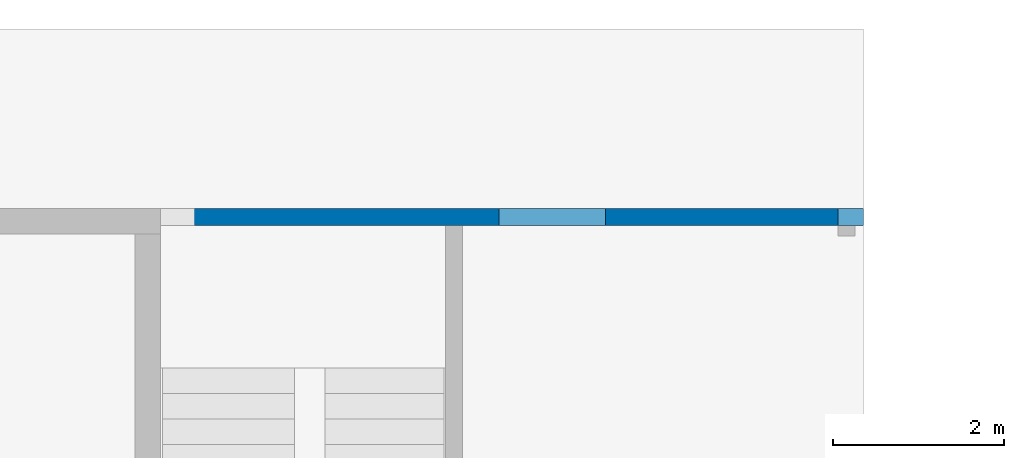
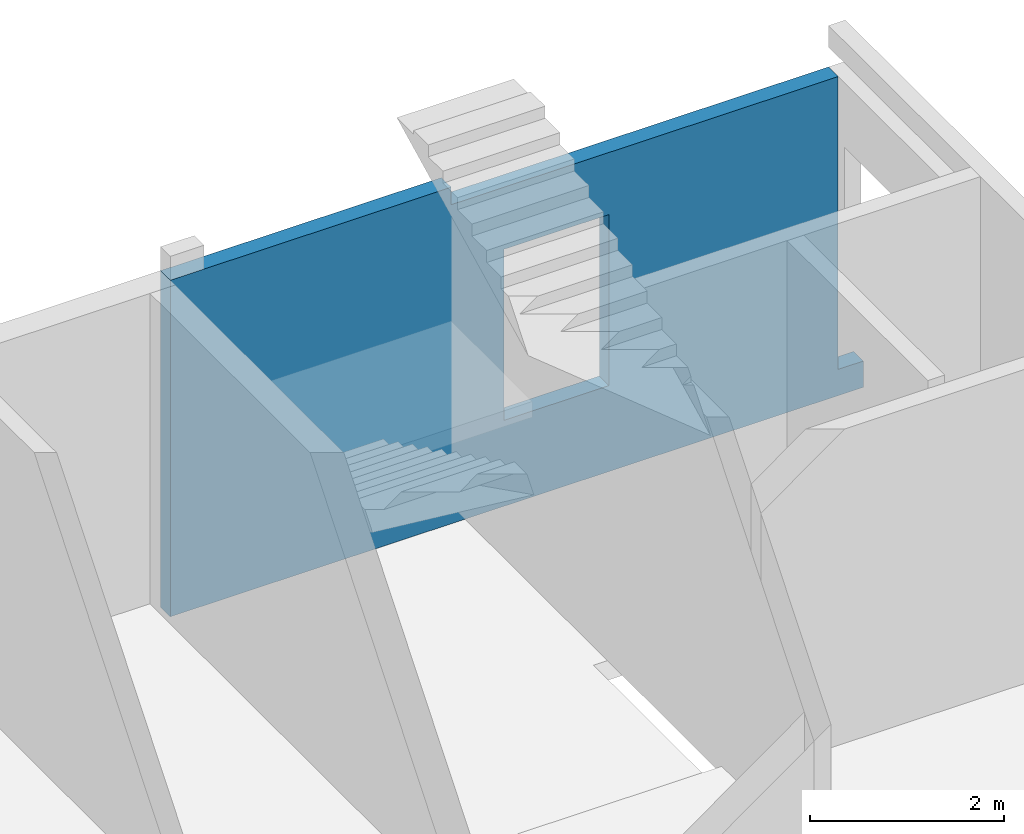
# One storey, part 8 of 8: 1 wall, 13 openings.
"""IFC4 building model written with IfcOpenShell, lengths in millimetres."""

from ifc_helpers import new_model, entity, si_unit, converted_unit, derived_unit, direction, frame, origin, place, context, subcontext, project, spatial, indexed_curve, outline, extrude, polygons, material, type_object, element, save


model = new_model("IFC4")

# Units and contexts
model_context = context("Model", 3, precision=0.01, world=origin(), true_north=direction((6.12303176911189e-17, 1.0)))
plan_context = context("Plan", 3, precision=0.01, world=origin(), true_north=direction((6.12303176911189e-17, 1.0)))
body_context = subcontext(model_context, "Body", "Model", "MODEL_VIEW")
ifc_project = project(units=[si_unit("LENGTHUNIT", "METRE", prefix="MILLI"), si_unit("AREAUNIT", "SQUARE_METRE"), si_unit("VOLUMEUNIT", "CUBIC_METRE"), converted_unit("PLANEANGLEUNIT", "DEGREE", entity("IfcRatioMeasure", 0.0174532925199433), si_unit("PLANEANGLEUNIT", "RADIAN"), dimensions=[0, 0, 0, 0, 0, 0, 0]), si_unit("MASSUNIT", "GRAM", prefix="KILO"), derived_unit("MASSDENSITYUNIT", [(si_unit("MASSUNIT", "GRAM", prefix="KILO"), 1), (si_unit("LENGTHUNIT", "METRE"), -3)]), derived_unit("MOMENTOFINERTIAUNIT", [(si_unit("LENGTHUNIT", "METRE"), 4)]), si_unit("TIMEUNIT", "SECOND"), si_unit("FREQUENCYUNIT", "HERTZ"), si_unit("THERMODYNAMICTEMPERATUREUNIT", "DEGREE_CELSIUS"), derived_unit("THERMALTRANSMITTANCEUNIT", [(si_unit("MASSUNIT", "GRAM", prefix="KILO"), 1), (si_unit("THERMODYNAMICTEMPERATUREUNIT", "KELVIN"), -1), (si_unit("TIMEUNIT", "SECOND"), -3)]), derived_unit("VOLUMETRICFLOWRATEUNIT", [(si_unit("LENGTHUNIT", "METRE"), 3), (si_unit("TIMEUNIT", "SECOND"), -1)]), derived_unit("MASSFLOWRATEUNIT", [(si_unit("MASSUNIT", "GRAM", prefix="KILO"), 1), (si_unit("TIMEUNIT", "SECOND"), -1)]), derived_unit("ROTATIONALFREQUENCYUNIT", [(si_unit("TIMEUNIT", "SECOND"), -1)]), si_unit("ELECTRICCURRENTUNIT", "AMPERE"), si_unit("ELECTRICVOLTAGEUNIT", "VOLT"), si_unit("POWERUNIT", "WATT"), si_unit("FORCEUNIT", "NEWTON", prefix="KILO"), si_unit("ILLUMINANCEUNIT", "LUX"), si_unit("LUMINOUSFLUXUNIT", "LUMEN"), si_unit("LUMINOUSINTENSITYUNIT", "CANDELA"), derived_unit("USERDEFINED", [(si_unit("MASSUNIT", "GRAM", prefix="KILO"), -1), (si_unit("LENGTHUNIT", "METRE"), -2), (si_unit("TIMEUNIT", "SECOND"), 3), (si_unit("LUMINOUSFLUXUNIT", "LUMEN"), 1)]), derived_unit("LINEARVELOCITYUNIT", [(si_unit("LENGTHUNIT", "METRE"), 1), (si_unit("TIMEUNIT", "SECOND"), -1)]), si_unit("PRESSUREUNIT", "PASCAL"), derived_unit("USERDEFINED", [(si_unit("LENGTHUNIT", "METRE"), -2), (si_unit("MASSUNIT", "GRAM", prefix="KILO"), 1), (si_unit("TIMEUNIT", "SECOND"), -2)]), derived_unit("LINEARFORCEUNIT", [(si_unit("MASSUNIT", "GRAM", prefix="KILO"), 1), (si_unit("LENGTHUNIT", "METRE"), 1), (si_unit("TIMEUNIT", "SECOND"), -2), (si_unit("LENGTHUNIT", "METRE"), -1)]), derived_unit("PLANARFORCEUNIT", [(si_unit("MASSUNIT", "GRAM", prefix="KILO"), 1), (si_unit("LENGTHUNIT", "METRE"), 1), (si_unit("TIMEUNIT", "SECOND"), -2), (si_unit("LENGTHUNIT", "METRE"), -2)])], contexts=[model_context, plan_context])

# Site, building, storey
site_placement = place(None, origin())
site = spatial("IfcSite", under=ifc_project, at=site_placement, CompositionType="ELEMENT")
building_placement = place(site_placement, origin())
building = spatial("IfcBuilding", under=site, at=building_placement, CompositionType="ELEMENT")
storey_placement = place(building_placement, origin())
storey = spatial("IfcBuildingStorey", under=building, at=storey_placement, Name="01", CompositionType="ELEMENT", Elevation=0.0)

# Wall, openings
ifc_material = material()
wall_type = type_object("IfcWallType", Name=":ADSK_ 25_200", PredefinedType="STANDARD")
wall_placement = place(storey_placement, frame((73670.0, 20400.0, -480.0), z_axis=(0.0, 0.0, 1.0), x_axis=(-1.0, 0.0, 0.0)))
wall = element("IfcWall", 1, at=wall_placement, inside=storey, type_object=wall_type, material=ifc_material, Name=":ADSK_ 25_200", ObjectType=":ADSK_ 25_200", PredefinedType="NOTDEFINED", context=body_context, shape_type="Tessellation", body=[
    polygons([(-4.19026652712969e-13, -99.9999999999989, 2.70716782324598e-13), (8240.00000000001, -99.9999999999989, 2.70716782324598e-13), (8240.00000000001, -99.9999999999989, 330.0), (8240.00000000001, -99.9999999999989, 4230.0), (7839.99999999997, -99.9999999999989, 4230.0), (4900.0, -99.9999999999946, 4230.0), (4900.0, -99.9999999999946, 4010.0), (300.000000000009, -99.9999999999989, 4010.0), (300.000000000009, -99.9999999999989, 330.0), (100.000000000012, -99.9999999999989, 330.0), (-4.19026652712969e-13, -99.9999999999989, 330.0), (3025.00000000001, -99.9999999999989, 3229.99999999804), (4275.00000000001, -99.9999999999989, 3229.99999999804), (4275.00000000001, -99.9999999999989, 1080.0), (3025.00000000001, -99.9999999999989, 1080.0), (8240.00000000001, 99.9999999999989, 2.70716782324598e-13), (300.0, 99.9999999999989, 2.70716782324598e-13), (-1.09107028414708e-12, 99.9999999999989, 2.70716782324598e-13), (-1.09107028414708e-12, 99.9999999999989, 330.0), (300.000000000009, 99.9999999999989, 330.0), (300.000000000009, 99.9999999999989, 4010.0), (4900.0, 100.000000000003, 4010.0), (4900.0, 100.000000000003, 4230.0), (7839.99999999997, 99.9999999999989, 4230.0), (8240.00000000001, 99.9999999999989, 4230.0), (8240.00000000001, 99.9999999999989, 2550.0), (8240.00000000001, 99.9999999999989, 2350.0), (4275.00000000001, 99.9999999999989, 3229.99999999804), (3025.00000000001, 99.9999999999989, 3229.99999999804), (3025.00000000001, 99.9999999999989, 1080.0), (4275.00000000001, 99.9999999999989, 1080.0)], [[[1, 2, 3, 4, 5, 6, 7, 8, 9, 10, 11], [12, 13, 14, 15]], [[16, 17, 18, 19, 20, 21, 22, 23, 24, 25, 26, 27], [28, 29, 30, 31]], [[2, 1, 18, 17, 16]], [[4, 3, 2, 16, 27, 26, 25]], [[4, 25, 24, 23, 6, 5]], [[20, 19, 11, 10, 9]], [[18, 1, 11, 19]], [[20, 9, 8, 21]], [[7, 22, 21, 8]], [[22, 7, 6, 23]], [[12, 29, 28, 13]], [[13, 28, 31, 14]], [[14, 31, 30, 15]], [[29, 12, 15, 30]]], closed=True),
])
placement = place(wall_placement, origin())
element("IfcOpeningElement", 2, at=placement, cuts=wall, Name=":ADSK_ 25_200", PredefinedType="OPENING", context=body_context, shape_type="SweptSolid", body=[
    extrude(outline(indexed_curve([(-850.000000000002, -849.999999999994), (850.0, -849.999999999994), (850.0, 849.999999999994), (-850.000000000002, 849.999999999994), (-850.000000000002, -849.999999999994)], self_intersect=False)), frame((54250.0, -100.0, 2180.0), z_axis=(0.0, 1.0, 0.0), x_axis=(1.0, 0.0, 0.0)), (0.0, 0.0, 1.0), 200.000000000959),
])
element("IfcOpeningElement", 3, at=placement, cuts=wall, Name=":ADSK_ 25_200", PredefinedType="OPENING", context=body_context, shape_type="SweptSolid", body=[
    extrude(outline(indexed_curve([(-850.000000000002, -849.999999999994), (849.999999999997, -849.999999999994), (849.999999999997, 849.999999999994), (-850.000000000002, 849.999999999994), (-850.000000000002, -849.999999999994)], self_intersect=False)), frame((50950.0, -100.0, 2180.0), z_axis=(0.0, 1.0, 0.0), x_axis=(1.0, 0.0, 0.0)), (0.0, 0.0, 1.0), 200.000000000959),
])
element("IfcOpeningElement", 4, at=placement, cuts=wall, Name=":ADSK_ 25_200", PredefinedType="OPENING", context=body_context, shape_type="SweptSolid", body=[
    extrude(outline(indexed_curve([(-850.000000000002, -849.999999999994), (849.999999999997, -849.999999999994), (849.999999999997, 849.999999999994), (-850.000000000002, 849.999999999994), (-850.000000000002, -849.999999999994)], self_intersect=False)), frame((47650.0, -100.0, 2180.0), z_axis=(0.0, 1.0, 0.0), x_axis=(1.0, 0.0, 0.0)), (0.0, 0.0, 1.0), 200.000000000959),
])
element("IfcOpeningElement", 5, at=placement, cuts=wall, Name=":ADSK_ 25_200", PredefinedType="OPENING", context=body_context, shape_type="SweptSolid", body=[
    extrude(outline(indexed_curve([(-850.000000000002, -849.999999999994), (849.999999999997, -849.999999999994), (849.999999999997, 849.999999999994), (-850.000000000002, 849.999999999994), (-850.000000000002, -849.999999999994)], self_intersect=False)), frame((44350.0, -100.0, 2180.0), z_axis=(0.0, 1.0, 0.0), x_axis=(1.0, 0.0, 0.0)), (0.0, 0.0, 1.0), 200.000000000959),
])
element("IfcOpeningElement", 6, at=placement, cuts=wall, Name=":ADSK_ 25_200", PredefinedType="OPENING", context=body_context, shape_type="SweptSolid", body=[
    extrude(outline(indexed_curve([(-849.999999999997, -849.999999999994), (850.000000000002, -849.999999999994), (850.000000000002, 849.999999999994), (-849.999999999997, 849.999999999994), (-849.999999999997, -849.999999999994)], self_intersect=False)), frame((41050.0, -100.0, 2180.0), z_axis=(0.0, 1.0, 0.0), x_axis=(1.0, 0.0, 0.0)), (0.0, 0.0, 1.0), 200.000000000959),
])
element("IfcOpeningElement", 7, at=placement, cuts=wall, Name=":ADSK_ 25_200", PredefinedType="OPENING", context=body_context, shape_type="SweptSolid", body=[
    extrude(outline(indexed_curve([(-849.999999999997, -849.999999999994), (850.000000000006, -849.999999999994), (850.000000000006, 849.999999999994), (-849.999999999997, 849.999999999994), (-849.999999999997, -849.999999999994)], self_intersect=False)), frame((34250.0, -100.0, 2180.0), z_axis=(0.0, 1.0, 0.0), x_axis=(1.0, 0.0, 0.0)), (0.0, 0.0, 1.0), 200.000000000959),
])
element("IfcOpeningElement", 8, at=placement, cuts=wall, Name=":ADSK_ 25_200", PredefinedType="OPENING", context=body_context, shape_type="SweptSolid", body=[
    extrude(outline(indexed_curve([(-850.000000000006, -849.999999999994), (849.999999999997, -849.999999999994), (849.999999999997, 849.999999999994), (-850.000000000006, 849.999999999994), (-850.000000000006, -849.999999999994)], self_intersect=False)), frame((30750.0, -100.0, 2180.0), z_axis=(0.0, 1.0, 0.0), x_axis=(1.0, 0.0, 0.0)), (0.0, 0.0, 1.0), 200.000000000959),
])
element("IfcOpeningElement", 9, at=placement, cuts=wall, Name=":ADSK_ 25_200", PredefinedType="OPENING", context=body_context, shape_type="SweptSolid", body=[
    extrude(outline(indexed_curve([(-849.999999999997, -849.999999999994), (850.000000000006, -849.999999999994), (850.000000000006, 849.999999999994), (-849.999999999997, 849.999999999994), (-849.999999999997, -849.999999999994)], self_intersect=False)), frame((27450.0, -100.0, 2180.0), z_axis=(0.0, 1.0, 0.0), x_axis=(1.0, 0.0, 0.0)), (0.0, 0.0, 1.0), 200.000000000959),
])
element("IfcOpeningElement", 10, at=placement, cuts=wall, Name=":ADSK_ 25_200", PredefinedType="OPENING", context=body_context, shape_type="SweptSolid", body=[
    extrude(outline(indexed_curve([(-849.999999999997, -849.999999999994), (850.000000000006, -849.999999999994), (850.000000000006, 849.999999999994), (-849.999999999997, 849.999999999994), (-849.999999999997, -849.999999999994)], self_intersect=False)), frame((24150.0, -100.0, 2180.0), z_axis=(0.0, 1.0, 0.0), x_axis=(1.0, 0.0, 0.0)), (0.0, 0.0, 1.0), 200.000000000959),
])
element("IfcOpeningElement", 11, at=placement, cuts=wall, Name=":ADSK_ 25_200", PredefinedType="OPENING", context=body_context, shape_type="SweptSolid", body=[
    extrude(outline(indexed_curve([(-849.999999999997, -849.999999999994), (850.000000000002, -849.999999999994), (850.000000000002, 849.999999999994), (-849.999999999997, 849.999999999994), (-849.999999999997, -849.999999999994)], self_intersect=False)), frame((37750.0, -100.0, 2180.0), z_axis=(0.0, 1.0, 0.0), x_axis=(1.0, 0.0, 0.0)), (0.0, 0.0, 1.0), 200.000000000959),
])
element("IfcOpeningElement", 12, at=placement, cuts=wall, Name=":ADSK_ 25_200", PredefinedType="OPENING", context=body_context, shape_type="SweptSolid", body=[
    extrude(outline(indexed_curve([(-1349.99999999902, -2100.0), (1349.99999999902, -2100.0), (1349.99999999902, 2100.0), (-1349.99999999902, 2100.0), (-1349.99999999902, -2100.0)], self_intersect=False)), frame((60270.0, -200.0, 1680.0), z_axis=(0.0, 1.0, 0.0), x_axis=(0.0, 0.0, -1.0)), (0.0, 0.0, 1.0), 400.000000001945),
])
element("IfcOpeningElement", 13, at=placement, cuts=wall, Name=":ADSK_ 25_200", PredefinedType="OPENING", context=body_context, shape_type="SweptSolid", body=[
    extrude(outline(indexed_curve([(-849.999999999997, -849.999999999994), (850.000000000006, -849.999999999994), (850.000000000006, 849.999999999994), (-849.999999999997, 849.999999999994), (-849.999999999997, -849.999999999994)], self_intersect=False)), frame((20850.0, -100.0, 2180.0), z_axis=(0.0, 1.0, 0.0), x_axis=(1.0, 0.0, 0.0)), (0.0, 0.0, 1.0), 200.000000000959),
])
opening_13_placement = place(wall_placement, frame((73670.0, 20400.0, 480.0), z_axis=(0.0, 0.0, 1.0), x_axis=(-1.0, 0.0, 0.0)))
element("IfcOpeningElement", 14, at=opening_13_placement, cuts=wall, Name=":ADSK_ 25_200", PredefinedType="OPENING", context=body_context, shape_type="SweptSolid", body=[
    extrude(outline(indexed_curve([(-624.999999999996, -1074.99999999902), (625.000000000005, -1074.99999999902), (625.000000000005, 1074.99999999902), (-624.999999999996, 1074.99999999902), (-624.999999999996, -1074.99999999902)], self_intersect=False)), frame((70020.0, 20600.0, 1675.0), z_axis=(0.0, -1.0, 0.0), x_axis=(-1.0, 0.0, 0.0)), (0.0, 0.0, 1.0), 400.000000001945),
])

save(model, "model.ifc")
